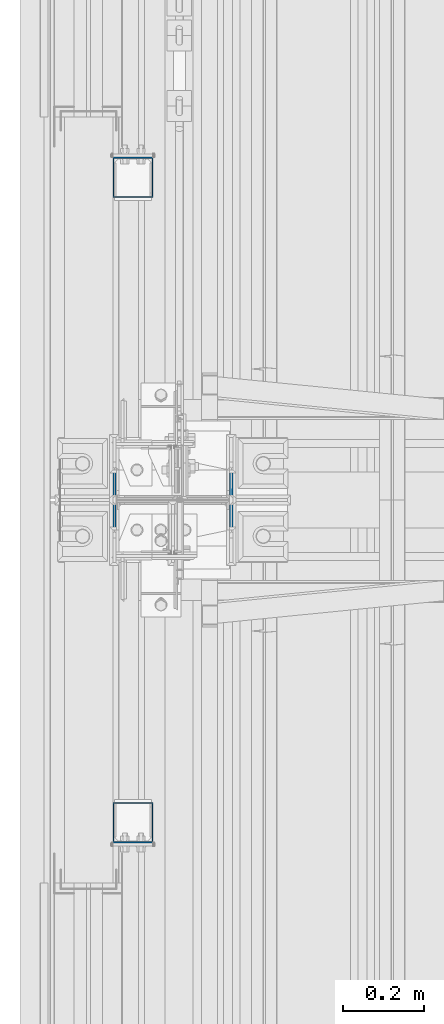
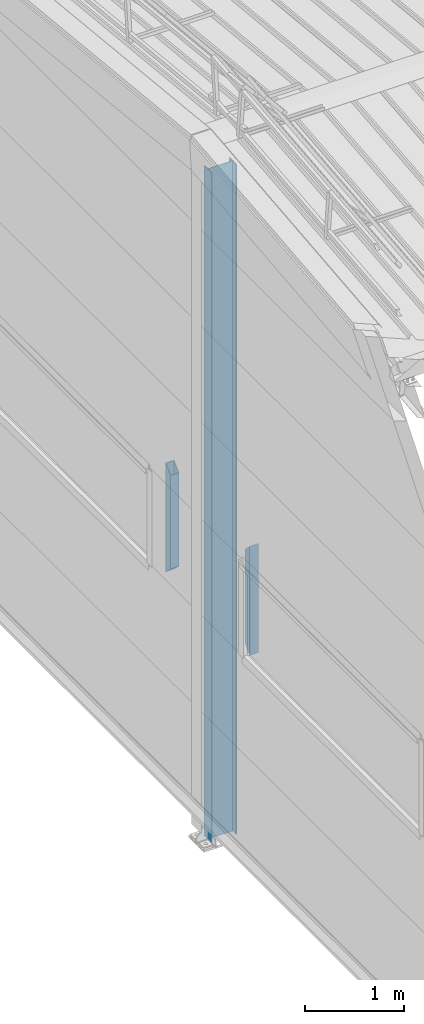
# One storey, part 227 of 709: 3 columns, 1 opening, 3 elements without a shape of their own.
"""IFC4 building model written with IfcOpenShell, lengths in millimetres."""

from ifc_helpers import new_model, si_unit, direction, frame, origin_with_axes, place, context, subcontext, project, spatial, line, indexed_curve, outline, extrude, polygons, material, element, aggregate, save


model = new_model("IFC4")

# Units and contexts
model_context = context("Model", 3, precision=0.2, world=origin_with_axes(), true_north=direction((0.0, 1.0)))
body_context = subcontext(model_context, "Body", "Model", "MODEL_VIEW")
reference_context = subcontext(model_context, "Reference", "Model", "MODEL_VIEW")
ifc_project = project(units=[si_unit("LENGTHUNIT", "METRE", prefix="MILLI"), si_unit("AREAUNIT", "SQUARE_METRE"), si_unit("VOLUMEUNIT", "CUBIC_METRE"), si_unit("MASSUNIT", "GRAM", prefix="KILO"), si_unit("TIMEUNIT", "SECOND"), si_unit("PLANEANGLEUNIT", "RADIAN"), si_unit("SOLIDANGLEUNIT", "STERADIAN"), si_unit("THERMODYNAMICTEMPERATUREUNIT", "DEGREE_CELSIUS"), si_unit("LUMINOUSINTENSITYUNIT", "LUMEN")], contexts=[model_context])

# Site, building, storey
site_placement = place(None, origin_with_axes())
site = spatial("IfcSite", under=ifc_project, at=site_placement, CompositionType="ELEMENT")
building_placement = place(site_placement, origin_with_axes())
building = spatial("IfcBuilding", under=site, at=building_placement, Name="Undefined", CompositionType="ELEMENT")
storey_placement = place(building_placement, origin_with_axes())
storey = spatial("IfcBuildingStorey", under=building, at=storey_placement, Name="Undefined", CompositionType="ELEMENT", Elevation=0.0)

# Assembly, column
assembly_1_placement = place(storey_placement, frame((50.0, 11800.0, 2600.0), z_axis=(0.0, -1.0, 0.0), x_axis=(0.0, 0.0, 1.0)))
assembly_1 = element("IfcElementAssembly", 1, at=assembly_1_placement, inside=storey)
ifc_material_1 = material(Name="C355", Category="STEEL")
column_1_placement = place(assembly_1_placement, origin_with_axes())
column_1 = element("IfcColumn", 2, at=column_1_placement, material=ifc_material_1, ObjectType="493", context=body_context, shape_type="Tessellation", body=[
    polygons([(10.0, -50.0, -50.0), (10.0, 50.0, -50.0), (1360.0, 50.0, -50.0), (1360.0, -50.0, -50.0), (110.0, -50.0, 50.0), (1260.0, -50.0, 50.0), (110.0, 50.0, 50.0), (1260.0, 50.0, 50.0), (107.0, 47.0, 47.0), (13.0, 47.0, -47.0), (1357.0, 47.0, -47.0), (1263.0, 47.0, 47.0), (107.0, -47.0, 47.0), (1263.0, -47.0, 47.0), (13.0, -47.0, -47.0), (1357.0, -47.0, -47.0)], [[[1, 2, 3, 4]], [[5, 1, 4, 6]], [[7, 5, 6, 8]], [[2, 7, 8, 3]], [[1, 5, 7, 2], [15, 10, 9, 13]], [[9, 10, 11, 12]], [[13, 9, 12, 14]], [[15, 13, 14, 16]], [[10, 15, 16, 11]], [[6, 4, 3, 8], [14, 12, 11, 16]]], closed=True),
])
aggregate(assembly_1, [column_1])

# Assembly, column, voiding feature
assembly_2_placement = place(storey_placement, frame((149.0, 11000.0, -200.0), z_axis=(0.0, -1.0, 0.0), x_axis=(0.0, 0.0, 1.0)))
assembly_2 = element("IfcElementAssembly", 3, at=assembly_2_placement, inside=storey)
ifc_material_2 = material(Name="C255-4", Category="STEEL")
column_2_placement = place(assembly_2_placement, origin_with_axes())
column_2 = element("IfcColumn", 4, at=column_2_placement, material=ifc_material_2, ObjectType="415", context=body_context, shape_type="Tessellation", body=[
    polygons([(8307.86561, 149.0, 0.0), (8307.86561, -149.0, 0.0), (8300.41561, -149.0, -74.5), (8300.41561, -141.0, -74.5), (8307.59061, -141.0, -2.75), (8307.59061, 141.0, -2.75), (8300.41561, 141.0, -74.5), (8300.41561, 149.0, -74.5), (8300.41561, 149.0, 74.5), (8300.41561, 141.0, 74.5), (8307.59061, 141.0, 2.75), (8307.59061, -141.0, 2.75), (8300.41561, -141.0, 74.5), (8300.41561, -149.0, 74.5), (25.0, -149.0, 74.5), (25.0, -141.0, 74.5), (25.0, -141.0, 2.75), (25.0, 141.0, 2.75), (25.0, 141.0, 74.5), (25.0, 149.0, 74.5), (25.0, 149.0, -74.5), (25.0, 141.0, -74.5), (25.0, 141.0, -2.75), (25.0, -141.0, -2.75), (25.0, -141.0, -74.5), (25.0, -149.0, -74.5)], [[[1, 2, 3, 4, 5, 6, 7, 8]], [[9, 10, 11, 12, 13, 14, 2, 1]], [[15, 16, 17, 18, 19, 20, 21, 22, 23, 24, 25, 26]], [[22, 21, 8, 7]], [[23, 22, 7, 6]], [[24, 23, 6, 5]], [[25, 24, 5, 4]], [[26, 25, 4, 3]], [[15, 26, 3, 2, 14]], [[16, 15, 14, 13]], [[17, 16, 13, 12]], [[18, 17, 12, 11]], [[19, 18, 11, 10]], [[20, 19, 10, 9]], [[21, 20, 9, 1, 8]]], closed=True),
])
voiding_feature_placement = place(column_2_placement, frame((8307.86561, 0.0, 0.0), z_axis=(0.0, 1.0, 0.0), x_axis=(-0.099503719, 0.0, 0.9950371902)))
element("IfcVoidingFeature", 5, at=voiding_feature_placement, cuts=column_2, PredefinedType="HOLE", context=reference_context, identifier="Reference", shape_type="SolidModel", body=[
    extrude(outline(indexed_curve([(0.0, 0.0), (124.5, 0.0), (89.1068, 353.93201), (-157.42785, 329.27854), (-122.03465, -24.65347)], segments=[line(1, 2, 3, 4, 5, 1)])), frame((0.0, 0.0, 149.0), z_axis=(0.0, 0.0, 1.0), x_axis=(1.0, 0.0, 0.0)), (0.0, 0.0, -1.0), 298.0),
])
aggregate(assembly_2, [column_2])

# Assembly, column
assembly_3_placement = place(storey_placement, frame((50.0, 10200.0, 2600.0), z_axis=(0.0, -1.0, 0.0), x_axis=(0.0, 0.0, 1.0)))
assembly_3 = element("IfcElementAssembly", 6, at=assembly_3_placement, inside=storey)
column_3_placement = place(assembly_3_placement, origin_with_axes())
column_3 = element("IfcColumn", 7, at=column_3_placement, material=ifc_material_1, ObjectType="493", context=body_context, shape_type="Tessellation", body=[
    polygons([(10.0, -50.0, 50.0), (110.0, -50.0, -50.0), (1260.0, -50.0, -50.0), (1360.0, -50.0, 50.0), (10.0, 50.0, 50.0), (1360.0, 50.0, 50.0), (110.0, 50.0, -50.0), (1260.0, 50.0, -50.0), (13.0, -47.0, 47.0), (13.0, 47.0, 47.0), (1357.0, 47.0, 47.0), (1357.0, -47.0, 47.0), (107.0, -47.0, -47.0), (1263.0, -47.0, -47.0), (107.0, 47.0, -47.0), (1263.0, 47.0, -47.0)], [[[1, 2, 3, 4]], [[5, 1, 4, 6]], [[7, 5, 6, 8]], [[2, 7, 8, 3]], [[1, 5, 7, 2], [9, 13, 15, 10]], [[9, 10, 11, 12]], [[13, 9, 12, 14]], [[15, 13, 14, 16]], [[10, 15, 16, 11]], [[3, 8, 6, 4], [14, 12, 11, 16]]], closed=True),
])
aggregate(assembly_3, [column_3])

save(model, "model.ifc")
